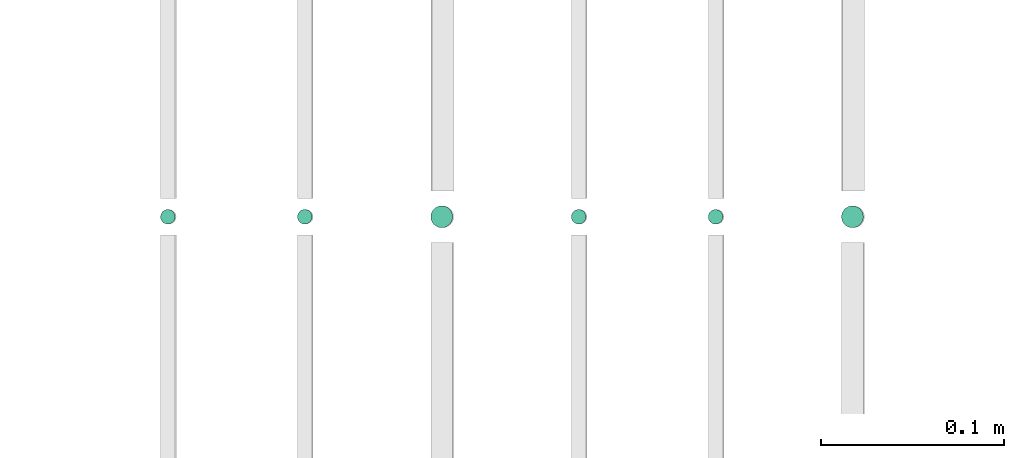
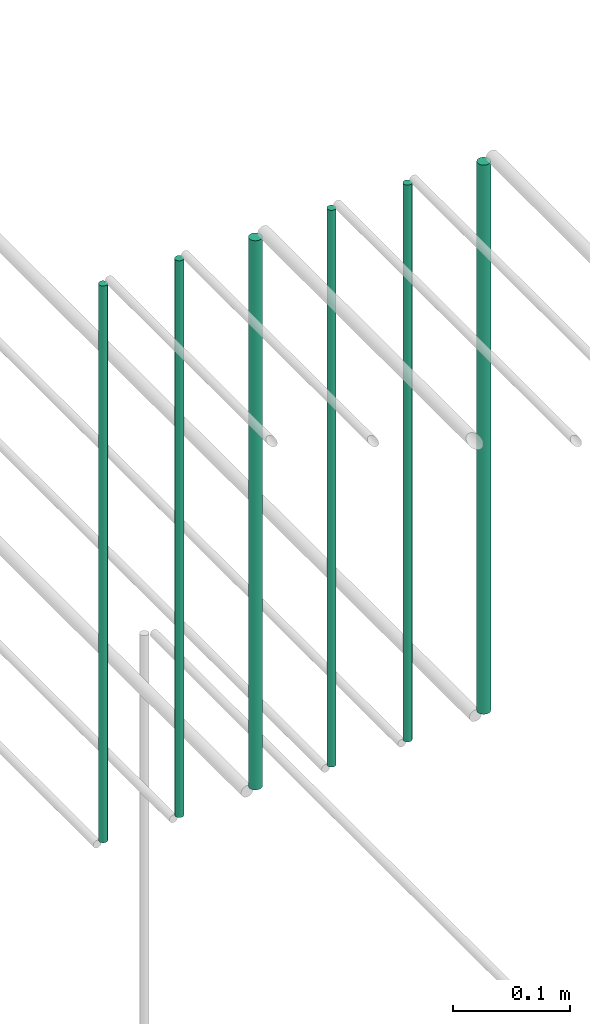
# One storey, part 195 of 331: 6 flow segments.
"""IFC2X3 building model written with IfcOpenShell, lengths in millimetres."""

from ifc_helpers import new_model, entity, si_unit, converted_unit, derived_unit, direction, frame, origin, origin_2d_with_axis, place, context, subcontext, project, spatial, circle, extrude, type_object, element, save


model = new_model("IFC2X3")

# Units and contexts
model_context = context("Model", 3, precision=0.01, world=origin(), true_north=direction((6.12303176911189e-17, 1.0)))
body_context = subcontext(model_context, "Body", "Model", "MODEL_VIEW")
ifc_project = project(units=[si_unit("LENGTHUNIT", "METRE", prefix="MILLI"), si_unit("AREAUNIT", "SQUARE_METRE"), si_unit("VOLUMEUNIT", "CUBIC_METRE"), converted_unit("PLANEANGLEUNIT", "DEGREE", entity("IfcRatioMeasure", 0.0174532925199433), si_unit("PLANEANGLEUNIT", "RADIAN"), dimensions=[0, 0, 0, 0, 0, 0, 0]), si_unit("MASSUNIT", "GRAM", prefix="KILO"), derived_unit("MASSDENSITYUNIT", [(si_unit("MASSUNIT", "GRAM", prefix="KILO"), 1), (si_unit("LENGTHUNIT", "METRE"), -3)]), derived_unit("MOMENTOFINERTIAUNIT", [(si_unit("LENGTHUNIT", "METRE"), 4)]), si_unit("TIMEUNIT", "SECOND"), si_unit("FREQUENCYUNIT", "HERTZ"), si_unit("THERMODYNAMICTEMPERATUREUNIT", "DEGREE_CELSIUS"), derived_unit("THERMALTRANSMITTANCEUNIT", [(si_unit("MASSUNIT", "GRAM", prefix="KILO"), 1), (si_unit("THERMODYNAMICTEMPERATUREUNIT", "KELVIN"), -1), (si_unit("TIMEUNIT", "SECOND"), -3)]), derived_unit("VOLUMETRICFLOWRATEUNIT", [(si_unit("LENGTHUNIT", "METRE"), 3), (si_unit("TIMEUNIT", "SECOND"), -1)]), derived_unit("MASSFLOWRATEUNIT", [(si_unit("MASSUNIT", "GRAM", prefix="KILO"), 1), (si_unit("TIMEUNIT", "SECOND"), -1)]), derived_unit("ROTATIONALFREQUENCYUNIT", [(si_unit("TIMEUNIT", "SECOND"), -1)]), si_unit("ELECTRICCURRENTUNIT", "AMPERE"), si_unit("ELECTRICVOLTAGEUNIT", "VOLT"), si_unit("POWERUNIT", "WATT"), si_unit("FORCEUNIT", "NEWTON", prefix="KILO"), si_unit("ILLUMINANCEUNIT", "LUX"), si_unit("LUMINOUSFLUXUNIT", "LUMEN"), si_unit("LUMINOUSINTENSITYUNIT", "CANDELA"), derived_unit("USERDEFINED", [(si_unit("MASSUNIT", "GRAM", prefix="KILO"), -1), (si_unit("LENGTHUNIT", "METRE"), -2), (si_unit("TIMEUNIT", "SECOND"), 3), (si_unit("LUMINOUSFLUXUNIT", "LUMEN"), 1)]), derived_unit("LINEARVELOCITYUNIT", [(si_unit("LENGTHUNIT", "METRE"), 1), (si_unit("TIMEUNIT", "SECOND"), -1)]), si_unit("PRESSUREUNIT", "PASCAL"), derived_unit("USERDEFINED", [(si_unit("LENGTHUNIT", "METRE"), -2), (si_unit("MASSUNIT", "GRAM", prefix="KILO"), 1), (si_unit("TIMEUNIT", "SECOND"), -2)]), derived_unit("LINEARFORCEUNIT", [(si_unit("MASSUNIT", "GRAM", prefix="KILO"), 1), (si_unit("LENGTHUNIT", "METRE"), 1), (si_unit("TIMEUNIT", "SECOND"), -2), (si_unit("LENGTHUNIT", "METRE"), -1)]), derived_unit("PLANARFORCEUNIT", [(si_unit("MASSUNIT", "GRAM", prefix="KILO"), 1), (si_unit("LENGTHUNIT", "METRE"), 1), (si_unit("TIMEUNIT", "SECOND"), -2), (si_unit("LENGTHUNIT", "METRE"), -2)])], contexts=[model_context])

# Site, building, storey
site_placement = place(None, frame((0.0, -0.00077364408347762, 0.0)))
site = spatial("IfcSite", under=ifc_project, at=site_placement, CompositionType="ELEMENT")
building_placement = place(site_placement, origin())
building = spatial("IfcBuilding", under=site, at=building_placement, CompositionType="ELEMENT")
storey_placement = place(building_placement, origin())
storey = spatial("IfcBuildingStorey", under=building, at=storey_placement, CompositionType="ELEMENT", Elevation=0.0)

# Flow segments
pipe_segment_type = type_object("IfcPipeSegmentType", PredefinedType="NOTDEFINED")
flow_segment_1_placement = place(storey_placement, frame((52664.4468045266, 5638.0252915914, 18460.0)))
element("IfcFlowSegment", 1, at=flow_segment_1_placement, inside=storey, type_object=pipe_segment_type, context=body_context, shape_type="SweptSolid", body=[
    extrude(circle(Radius=4.0, at=origin_2d_with_axis()), frame((5.59527223591499, 5.59527223591607, 0.0), z_axis=(0.0, 0.0, 1.0), x_axis=(-1.0, 0.0, 0.0)), (0.0, 0.0, 1.0), 580.000000000015),
])
flow_segment_2_placement = place(storey_placement, frame((52739.4468045266, 5638.0252915914, 18460.0)))
element("IfcFlowSegment", 2, at=flow_segment_2_placement, inside=storey, type_object=pipe_segment_type, context=body_context, shape_type="SweptSolid", body=[
    extrude(circle(Radius=4.0, at=origin_2d_with_axis()), frame((5.59527223591499, 5.59527223591607, 0.0), z_axis=(0.0, 0.0, 1.0), x_axis=(-1.0, 0.0, 0.0)), (0.0, 0.0, 1.0), 580.000000000007),
])
flow_segment_3_placement = place(storey_placement, frame((52812.4468045266, 5636.0252915914, 18464.0)))
element("IfcFlowSegment", 3, at=flow_segment_3_placement, inside=storey, type_object=pipe_segment_type, context=body_context, shape_type="SweptSolid", body=[
    extrude(circle(Radius=6.0, at=origin_2d_with_axis()), frame((7.59527223591454, 7.59527223591562, 0.0), z_axis=(0.0, 0.0, 1.0), x_axis=(-1.0, 0.0, 0.0)), (0.0, 0.0, 1.0), 572.000000000002),
])
flow_segment_4_placement = place(storey_placement, frame((52889.4468045266, 5638.0252915914, 18460.0)))
element("IfcFlowSegment", 4, at=flow_segment_4_placement, inside=storey, type_object=pipe_segment_type, context=body_context, shape_type="SweptSolid", body=[
    extrude(circle(Radius=4.0, at=origin_2d_with_axis()), frame((5.59527223591499, 5.59527223591607, 0.0), z_axis=(0.0, 0.0, 1.0), x_axis=(-1.0, 0.0, 0.0)), (0.0, 0.0, 1.0), 580.000000000015),
])
flow_segment_5_placement = place(storey_placement, frame((52964.4468045266, 5638.0252915914, 18460.0)))
element("IfcFlowSegment", 5, at=flow_segment_5_placement, inside=storey, type_object=pipe_segment_type, context=body_context, shape_type="SweptSolid", body=[
    extrude(circle(Radius=4.0, at=origin_2d_with_axis()), frame((5.59527223591499, 5.59527223591607, 0.0), z_axis=(0.0, 0.0, 1.0), x_axis=(-1.0, 0.0, 0.0)), (0.0, 0.0, 1.0), 580.0),
])
flow_segment_6_placement = place(storey_placement, frame((53037.4468045266, 5636.02529159141, 18464.0)))
element("IfcFlowSegment", 6, at=flow_segment_6_placement, inside=storey, type_object=pipe_segment_type, context=body_context, shape_type="SweptSolid", body=[
    extrude(circle(Radius=6.0, at=origin_2d_with_axis()), frame((7.59527223591454, 7.59527223591562, 0.0), z_axis=(0.0, 0.0, 1.0), x_axis=(-1.0, 0.0, 0.0)), (0.0, 0.0, 1.0), 572.000000000011),
])

save(model, "model.ifc")
